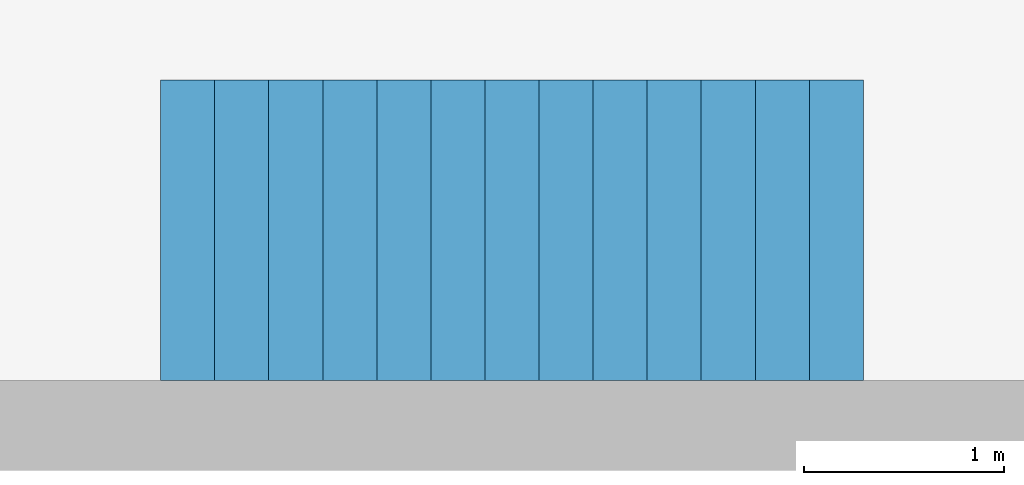
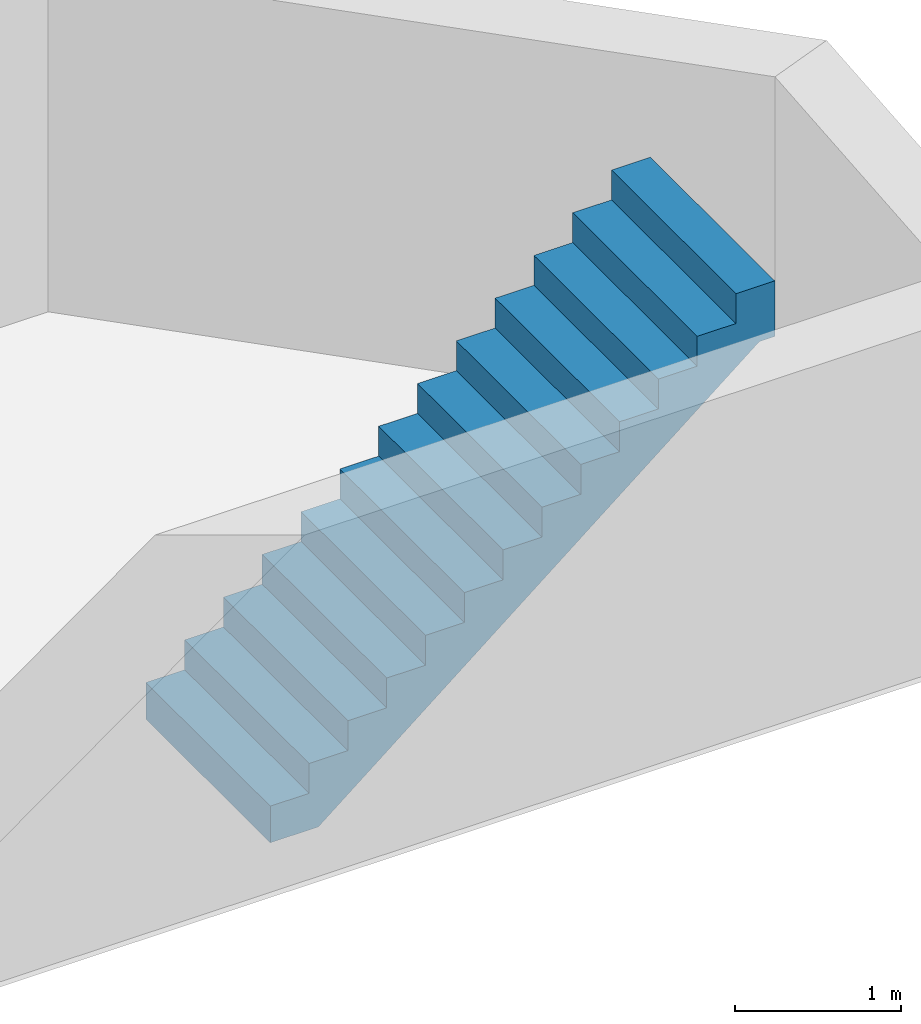
# One storey, part 2 of 2: 1 stair flight.
"""IFC4 building model written with IfcOpenShell, lengths in millimetres."""

import ifcopenshell
import ifcopenshell.guid

model = None  # the IFC model being written
_history = None  # IfcOwnerHistory: only IFC2X3 demands one
_inside = {}  # id of a spatial element -> (the spatial element, [elements in it])
_under = {}  # id of a project, library or spatial element -> (it, [spatial elements below it])
_declared = {}  # id of a project -> (the project, [libraries it declares])
_typed = {}  # id of a type object -> (the type object, [elements of that type])
_made_of = {}  # id of a material, layer set ... -> (it, [elements and type objects made of it])


def new_model(schema):
    """Start an empty IFC model of exactly this schema.

    Asked for "IFC4X3", IfcOpenShell would pick the latest addendum, in which some entities
    have other attributes; the version numbers below select the first issue.
    IFC2X3 requires an IfcOwnerHistory on every rooted entity: one is made here for all.
    """
    global model, _history
    if schema == "IFC4X3":
        model = ifcopenshell.file(schema_version=(4, 3, 0, 0))
    else:
        model = ifcopenshell.file(schema=schema)
    _inside.clear()
    _under.clear()
    _declared.clear()
    _typed.clear()
    _made_of.clear()
    _history = None
    if model.schema == "IFC2X3":
        org = make("IfcOrganization", Name="unknown")
        user = make(
            "IfcPersonAndOrganization",
            ThePerson=make("IfcPerson", FamilyName="unknown"),
            TheOrganization=org,
        )
        app = make(
            "IfcApplication",
            ApplicationDeveloper=org,
            Version="unknown",
            ApplicationFullName="unknown",
            ApplicationIdentifier="unknown",
        )
        _history = make(
            "IfcOwnerHistory",
            OwningUser=user,
            OwningApplication=app,
            ChangeAction="ADDED",
            CreationDate=0,
        )
    return model


def make(cls, **values):
    """One entity of the class cls with the attributes given. An attribute that is None is left unset."""
    return model.create_entity(
        cls, **{name: value for name, value in values.items() if value is not None}
    )


def entity(cls, *values):
    """Any entity or typed value of the class cls, its attributes in the order of the schema. None: left unset."""
    e = model.create_entity(cls)
    for i, value in enumerate(values):
        if value is not None:
            e[i] = value
    return e


def rooted(cls, **values):
    """An entity with a GlobalId (a new one), such as an element, a storey or a relation."""
    return make(cls, GlobalId=ifcopenshell.guid.new(), OwnerHistory=_history, **values)


def si_unit(unit_type, name, prefix=None):
    """IfcSIUnit, for example si_unit("LENGTHUNIT", "METRE", prefix="MILLI")."""
    return make("IfcSIUnit", UnitType=unit_type, Prefix=prefix, Name=name)


def converted_unit(unit_type, name, factor, base, dimensions=None, offset=None):
    """IfcConversionBasedUnit, such as the inch: factor (a typed value) times the base unit."""
    return make(
        "IfcConversionBasedUnit"
        if offset is None
        else "IfcConversionBasedUnitWithOffset",
        ConversionOffset=offset,
        Dimensions=None
        if dimensions is None
        else entity("IfcDimensionalExponents", *dimensions),
        UnitType=unit_type,
        Name=name,
        ConversionFactor=make(
            "IfcMeasureWithUnit", ValueComponent=factor, UnitComponent=base
        ),
    )


def assignment(units):
    """IfcUnitAssignment: the units of a project."""
    return None if units is None else make("IfcUnitAssignment", Units=units)


def point(xyz):
    """IfcCartesianPoint."""
    return None if xyz is None else make("IfcCartesianPoint", Coordinates=xyz)


def direction(xyz):
    """IfcDirection."""
    return None if xyz is None else make("IfcDirection", DirectionRatios=xyz)


def frame(location, z_axis=None, x_axis=None):
    """IfcAxis2Placement3D, a coordinate frame: its origin and axes. An axis left out is left unset."""
    return make(
        "IfcAxis2Placement3D",
        Location=point(location),
        Axis=direction(z_axis),
        RefDirection=direction(x_axis),
    )


def frame_2d(location, x_axis=None):
    """IfcAxis2Placement2D, a coordinate frame in the plane: its origin and x axis."""
    return make(
        "IfcAxis2Placement2D", Location=point(location), RefDirection=direction(x_axis)
    )


def origin_with_axes():
    """The frame at (0, 0, 0) with the z axis (0, 0, 1) and the x axis (1, 0, 0) written out."""
    return frame((0.0, 0.0, 0.0), z_axis=(0.0, 0.0, 1.0), x_axis=(1.0, 0.0, 0.0))


def origin_2d_with_axis():
    """The frame at (0, 0) in the plane with the x axis (1, 0) written out."""
    return frame_2d((0.0, 0.0), x_axis=(1.0, 0.0))


def place(relative_to, where):
    """IfcLocalPlacement: puts the frame where relative to a parent placement (None: the world)."""
    return make(
        "IfcLocalPlacement", PlacementRelTo=relative_to, RelativePlacement=where
    )


def context(
    kind, dimensions, precision=None, world=None, true_north=None, identifier=None
):
    """IfcGeometricRepresentationContext, for example the 3D "Model" context."""
    return make(
        "IfcGeometricRepresentationContext",
        ContextIdentifier=identifier,
        ContextType=kind,
        CoordinateSpaceDimension=dimensions,
        Precision=precision,
        WorldCoordinateSystem=world,
        TrueNorth=true_north,
    )


def subcontext(parent, identifier, kind, view, scale=None):
    """IfcGeometricRepresentationSubContext, for example "Body" below "Model"."""
    return make(
        "IfcGeometricRepresentationSubContext",
        ContextIdentifier=identifier,
        ContextType=kind,
        ParentContext=parent,
        TargetScale=scale,
        TargetView=view,
    )


def project(units=None, contexts=None):
    """IfcProject with its units and contexts."""
    return rooted(
        "IfcProject",
        Name="project",
        RepresentationContexts=contexts,
        UnitsInContext=assignment(units),
    )


def spatial(cls, under=None, at=None, **own):
    """A site, building, storey or space (cls), placed at a placement, below another one or the project."""
    s = rooted(cls, ObjectPlacement=at, **own)
    if under is not None:
        _under.setdefault(under.id(), (under, []))[1].append(s)
    return s


def point_list(points):
    """IfcCartesianPointList2D or 3D."""
    cls = (
        "IfcCartesianPointList2D" if len(points[0]) == 2 else "IfcCartesianPointList3D"
    )
    return make(cls, CoordList=points)


def polygons(points, faces, closed=None, point_numbers=None):
    """IfcPolygonalFaceSet: a face is its outer loop, then its inner loops; points numbered from 1."""
    made = []
    for loops in faces:
        if len(loops) == 1:
            made.append(make("IfcIndexedPolygonalFace", CoordIndex=loops[0]))
        else:
            made.append(
                make(
                    "IfcIndexedPolygonalFaceWithVoids",
                    CoordIndex=loops[0],
                    InnerCoordIndices=loops[1:],
                )
            )
    return make(
        "IfcPolygonalFaceSet",
        Coordinates=point_list(points),
        Closed=closed,
        Faces=made,
        PnIndex=point_numbers,
    )


def shape(context_of_items, identifier, shape_type, items):
    """IfcShapeRepresentation: the items that make up one representation, for example the "Body"."""
    return make(
        "IfcShapeRepresentation",
        ContextOfItems=context_of_items,
        RepresentationIdentifier=identifier,
        RepresentationType=shape_type,
        Items=items,
    )


def source(mapping_origin, context_of_items, identifier, shape_type, items):
    """IfcRepresentationMap: a shape defined once, which mapped items show again and again."""
    return make(
        "IfcRepresentationMap",
        MappingOrigin=mapping_origin,
        MappedRepresentation=shape(context_of_items, identifier, shape_type, items),
    )


def transform(
    local_origin,
    x_axis=None,
    y_axis=None,
    z_axis=None,
    scale=None,
    scale2=None,
    scale3=None,
    uniform=True,
):
    """IfcCartesianTransformationOperator3D, or its non-uniform kind. x_axis, y_axis, z_axis: its Axis1, 2, 3."""
    if uniform:
        return make(
            "IfcCartesianTransformationOperator3D",
            Axis1=direction(x_axis),
            Axis2=direction(y_axis),
            LocalOrigin=point(local_origin),
            Scale=scale,
            Axis3=direction(z_axis),
        )
    return make(
        "IfcCartesianTransformationOperator3DnonUniform",
        Axis1=direction(x_axis),
        Axis2=direction(y_axis),
        LocalOrigin=point(local_origin),
        Scale=scale,
        Axis3=direction(z_axis),
        Scale2=scale2,
        Scale3=scale3,
    )


def mapped(mapping_source, mapping_target):
    """IfcMappedItem: shows the shape of a source again, moved by a transform."""
    return make(
        "IfcMappedItem", MappingSource=mapping_source, MappingTarget=mapping_target
    )


def made_of(thing, what):
    """Note that an element or type object is made of a material, layer set ...; save() writes the relation."""
    if what is not None:
        _made_of.setdefault(what.id(), (what, []))[1].append(thing)
    return thing


def type_object(cls, material=None, **own):
    """A type object (cls), such as IfcWallType, which elements share."""
    return made_of(rooted(cls, **own), material)


def type_shapes(of_type, sources):
    """Give a type object the sources (RepresentationMaps) that its elements show as mapped items."""
    of_type.RepresentationMaps = sources


def element(
    cls,
    number,
    at=None,
    inside=None,
    cuts=None,
    type_object=None,
    material=None,
    context=None,
    identifier="Body",
    shape_type=None,
    held_by="IfcProductDefinitionShape",
    body=None,
    shapes=None,
    **own,
):
    """One element of the class cls, such as IfcWall. Its Tag is "e" and its number.

    at: its placement. inside: the storey or other place that contains it. cuts: it is an
    opening in that element (IfcRelVoidsElement). A single representation is given by context,
    identifier, shape_type and body (its items); several are given by shapes. held_by: the class
    of the entity that holds the representations. save() writes the other relations.
    """
    e = rooted(cls, Tag="e%d" % number, ObjectPlacement=at, **own)
    if body is not None:
        shapes = [shape(context, identifier, shape_type, body)]
    if shapes is not None:
        e.Representation = make(held_by, Representations=shapes)
    if inside is not None:
        _inside.setdefault(inside.id(), (inside, []))[1].append(e)
    if cuts is not None:
        rooted(
            "IfcRelVoidsElement", RelatingBuildingElement=cuts, RelatedOpeningElement=e
        )
    if type_object is not None:
        _typed.setdefault(type_object.id(), (type_object, []))[1].append(e)
    return made_of(e, material)


def aggregate(whole, parts):
    """IfcRelAggregates: a whole, such as a stair, and the parts it consists of."""
    return rooted("IfcRelAggregates", RelatingObject=whole, RelatedObjects=parts)


def save(model, path):
    """Write the relations noted so far, then the file.

    IfcRelAggregates (storeys below a building ...), IfcRelContainedInSpatialStructure (elements
    in a storey), IfcRelDefinesByType, IfcRelAssociatesMaterial and IfcRelDeclares: one each for
    every whole, place, type object, material and project.
    """
    for whole, parts in _under.values():
        aggregate(whole, parts)
    for where, things in _inside.values():
        rooted(
            "IfcRelContainedInSpatialStructure",
            RelatedElements=things,
            RelatingStructure=where,
        )
    for kind, things in _typed.values():
        rooted("IfcRelDefinesByType", RelatedObjects=things, RelatingType=kind)
    for what, things in _made_of.values():
        rooted("IfcRelAssociatesMaterial", RelatedObjects=things, RelatingMaterial=what)
    for by, libraries in _declared.values():
        rooted("IfcRelDeclares", RelatingContext=by, RelatedDefinitions=libraries)
    model.write(path)


model = new_model("IFC4")

# Units and contexts
model_context = context("Model", 3, precision=1e-05, world=origin_with_axes())
plan_context = context("Plan", 2, precision=1e-05, world=origin_2d_with_axis())
body_context = subcontext(model_context, "Body", "Model", "MODEL_VIEW")
ifc_project = project(units=[si_unit("VOLUMEUNIT", "CUBIC_METRE"), si_unit("LENGTHUNIT", "METRE", prefix="MILLI"), converted_unit("PLANEANGLEUNIT", "degree", entity("IfcReal", 0.0174532925199433), si_unit("PLANEANGLEUNIT", "RADIAN"), dimensions=[0, 0, 0, 0, 0, 0, 0]), si_unit("AREAUNIT", "SQUARE_METRE")], contexts=[model_context, plan_context])

# Site, building, storey
site_placement = place(None, origin_with_axes())
site = spatial("IfcSite", under=ifc_project, at=site_placement)
building_placement = place(site_placement, origin_with_axes())
building = spatial("IfcBuilding", under=site, at=building_placement, Name="Building")
storey_placement = place(building_placement, frame((0.0, 0.0, -2799.99995231628), z_axis=(0.0, 0.0, 1.0), x_axis=(1.0, 0.0, 0.0)))
storey = spatial("IfcBuildingStorey", under=building, at=storey_placement, Name="KG")

# Stair flight
stair_flight_type = type_object("IfcStairFlightType", Name="Keller", PredefinedType="STRAIGHT")
shared_shape = source(origin_with_axes(), body_context, "Body", "Tessellation", [
    polygons([(0.0, 0.0, 0.0), (0.0, 0.0, 219.615386962891), (270.0, 0.0, 219.615386962891), (270.0, 0.0, 439.230773925781), (540.0, 0.0, 439.230773925781), (540.0, 0.0, 658.84619140625), (810.0, 0.0, 658.84619140625), (810.0, 0.0, 878.461547851562), (1080.0, 0.0, 878.461547851562), (1080.0, 0.0, 1098.07702636719), (1350.0, 0.0, 1098.07702636719), (1350.0, 0.0, 1317.69250488281), (1619.99987792969, 0.0, 1317.69250488281), (1619.99987792969, 0.0, 1537.30786132812), (1889.99987792969, 0.0, 1537.30786132812), (1889.99987792969, 0.0, 1756.92333984375), (2160.0, 0.0, 1756.92333984375), (2160.0, 0.0, 1976.53881835938), (2430.0, 0.0, 1976.53881835938), (2430.0, 0.0, 2196.154296875), (2700.0, 0.0, 2196.154296875), (2700.0, 0.0, 2415.76977539062), (2970.0, 0.0, 2415.76977539062), (2970.0, 0.0, 2635.38525390625), (3239.99975585938, 0.0, 2635.38525390625), (3239.99975585938, 0.0, 2855.00048828125), (3509.99975585938, 0.0, 2855.00048828125), (3509.99975585938, 0.0, 2445.00048828125), (3402.12841796875, 0.0, 2445.00048828125), (334.719970703125, 0.0, -50.0), (0.0, 0.0, -50.0), (0.0, 1500.0, 219.615386962891), (270.0, 1500.0, 219.615386962891), (270.0, 1500.0, 439.230773925781), (540.0, 1500.0, 439.230773925781), (540.0, 1500.0, 658.84619140625), (810.0, 1500.0, 658.84619140625), (810.0, 1500.0, 878.461547851562), (1080.0, 1500.0, 878.461547851562), (1080.0, 1500.0, 1098.07702636719), (1350.0, 1500.0, 1098.07702636719), (1350.0, 1500.0, 1317.69250488281), (1619.99987792969, 1500.0, 1317.69250488281), (1619.99987792969, 1500.0, 1537.30786132812), (1889.99987792969, 1500.0, 1537.30786132812), (1889.99987792969, 1500.0, 1756.92333984375), (2160.0, 1500.0, 1756.92333984375), (2160.0, 1500.0, 1976.53881835938), (2430.0, 1500.0, 1976.53881835938), (2430.0, 1500.0, 2196.154296875), (2700.0, 1500.0, 2196.154296875), (2700.0, 1500.0, 2415.76977539062), (2970.0, 1500.0, 2415.76977539062), (2970.0, 1500.0, 2635.38525390625), (3239.99975585938, 1500.0, 2635.38525390625), (3239.99975585938, 1500.0, 2855.00048828125), (3509.99975585938, 1500.0, 2855.00048828125), (3509.99975585938, 1500.0, 2445.00048828125), (3402.12841796875, 1500.0, 2445.00048828125), (334.719970703125, 1500.0, -50.0), (0.0, 1500.0, -50.0), (0.0, 1500.0, 0.0)], [[[2, 1, 31, 30, 29, 28, 27, 26, 25, 24, 23, 22, 21, 20, 19, 18, 17, 16, 15, 14, 13, 12, 11, 10, 9, 8, 7, 6, 5, 4, 3]], [[32, 33, 34, 35, 36, 37, 38, 39, 40, 41, 42, 43, 44, 45, 46, 47, 48, 49, 50, 51, 52, 53, 54, 55, 56, 57, 58, 59, 60, 61, 62]], [[20, 21, 51, 50]], [[7, 8, 38, 37]], [[21, 22, 52, 51]], [[8, 9, 39, 38]], [[22, 23, 53, 52]], [[9, 10, 40, 39]], [[23, 24, 54, 53]], [[10, 11, 41, 40]], [[24, 25, 55, 54]], [[11, 12, 42, 41]], [[25, 26, 56, 55]], [[12, 13, 43, 42]], [[26, 27, 57, 56]], [[13, 14, 44, 43]], [[27, 28, 58, 57]], [[14, 15, 45, 44]], [[1, 2, 32, 62]], [[28, 29, 59, 58]], [[15, 16, 46, 45]], [[2, 3, 33, 32]], [[31, 1, 62, 61]], [[16, 17, 47, 46]], [[3, 4, 34, 33]], [[30, 31, 61, 60]], [[17, 18, 48, 47]], [[4, 5, 35, 34]], [[29, 30, 60, 59]], [[18, 19, 49, 48]], [[5, 6, 36, 35]], [[19, 20, 50, 49]], [[6, 7, 37, 36]]], closed=True),
])
type_shapes(stair_flight_type, [shared_shape])
stair_flight_placement = place(storey_placement, frame((12472.3711013794, 5749.99523162842, -0.000715255737304688), z_axis=(0.0, 0.0, 1.0), x_axis=(0.999999999999985, 1.74845553146949e-07, 0.0)))
element("IfcStairFlight", 1, at=stair_flight_placement, inside=storey, type_object=stair_flight_type, Name="StairFlight", NumberOfRisers=13, NumberOfTreads=12, PredefinedType="STRAIGHT", RiserHeight=219.615404422467, TreadLength=250.0, context=body_context, shape_type="MappedRepresentation", body=[
    mapped(shared_shape, transform((0.0, 0.0, 0.0), x_axis=(1.0, 0.0, 0.0), y_axis=(0.0, 1.0, 0.0), z_axis=(0.0, 0.0, 1.0), scale=1.0)),
])

save(model, "model.ifc")
